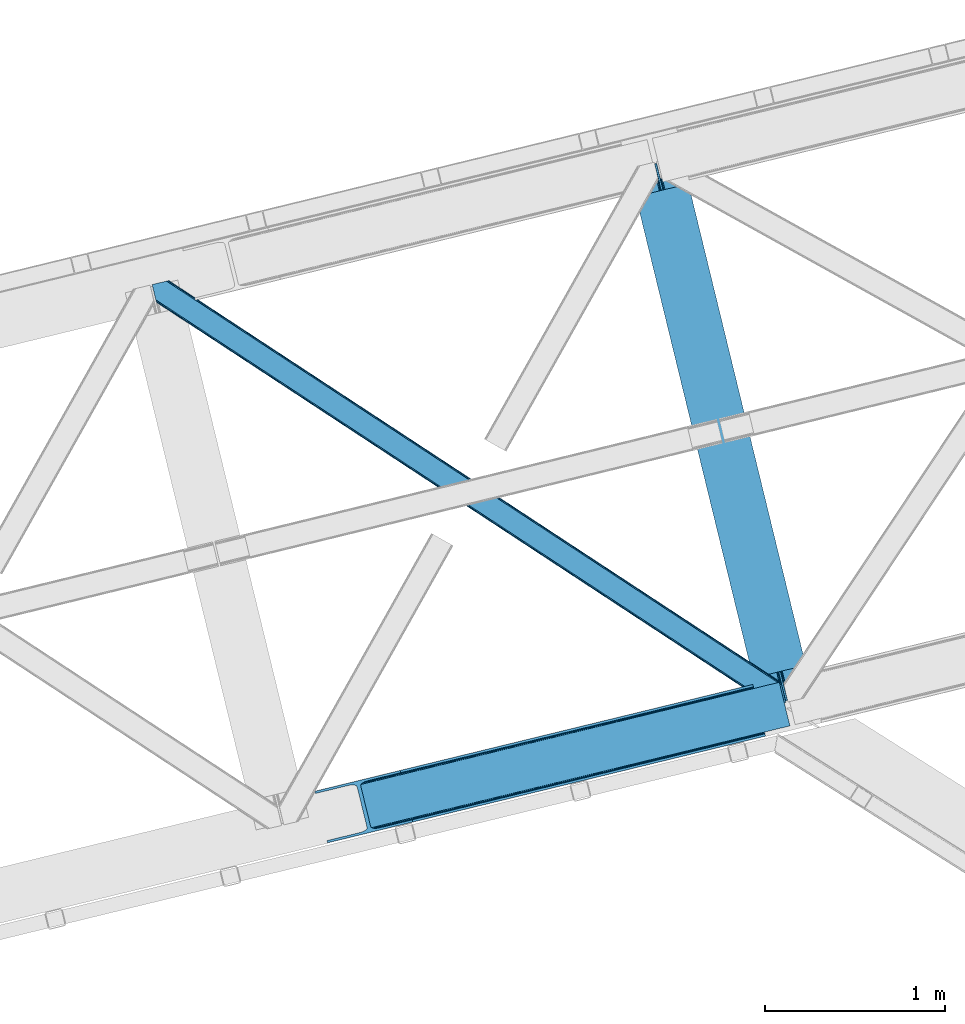
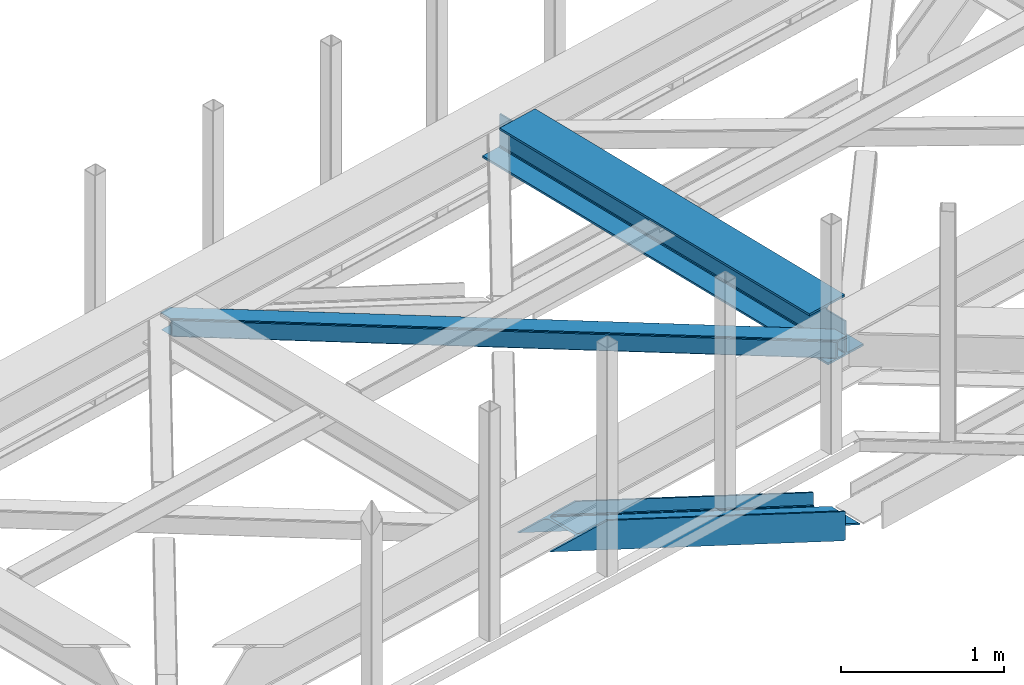
# One storey, part 56 of 67: 2 members, 1 beam.
"""IFC4 building model written with IfcOpenShell, lengths in millimetres."""

from ifc_helpers import new_model, entity, si_unit, converted_unit, derived_unit, direction, frame, origin, place, context, subcontext, project, spatial, triangles, polygons, material, type_object, element, save


model = new_model("IFC4")

# Units and contexts
model_context = context("Model", 3, precision=0.01, world=origin(), true_north=direction((6.12303176911189e-17, 1.0)))
plan_context = context("Plan", 3, precision=0.01, world=origin(), true_north=direction((6.12303176911189e-17, 1.0)))
body_context = subcontext(model_context, "Body", "Model", "MODEL_VIEW")
ifc_project = project(units=[si_unit("LENGTHUNIT", "METRE", prefix="MILLI"), si_unit("AREAUNIT", "SQUARE_METRE"), si_unit("VOLUMEUNIT", "CUBIC_METRE"), converted_unit("PLANEANGLEUNIT", "DEGREE", entity("IfcRatioMeasure", 0.0174532925199433), si_unit("PLANEANGLEUNIT", "RADIAN"), dimensions=[0, 0, 0, 0, 0, 0, 0]), si_unit("MASSUNIT", "GRAM", prefix="KILO"), derived_unit("MASSDENSITYUNIT", [(si_unit("MASSUNIT", "GRAM", prefix="KILO"), 1), (si_unit("LENGTHUNIT", "METRE"), -3)]), derived_unit("MOMENTOFINERTIAUNIT", [(si_unit("LENGTHUNIT", "METRE"), 4)]), si_unit("TIMEUNIT", "SECOND"), si_unit("FREQUENCYUNIT", "HERTZ"), si_unit("THERMODYNAMICTEMPERATUREUNIT", "DEGREE_CELSIUS"), derived_unit("THERMALTRANSMITTANCEUNIT", [(si_unit("MASSUNIT", "GRAM", prefix="KILO"), 1), (si_unit("THERMODYNAMICTEMPERATUREUNIT", "KELVIN"), -1), (si_unit("TIMEUNIT", "SECOND"), -3)]), derived_unit("VOLUMETRICFLOWRATEUNIT", [(si_unit("LENGTHUNIT", "METRE"), 3), (si_unit("TIMEUNIT", "SECOND"), -1)]), derived_unit("MASSFLOWRATEUNIT", [(si_unit("MASSUNIT", "GRAM", prefix="KILO"), 1), (si_unit("TIMEUNIT", "SECOND"), -1)]), derived_unit("ROTATIONALFREQUENCYUNIT", [(si_unit("TIMEUNIT", "SECOND"), -1)]), si_unit("ELECTRICCURRENTUNIT", "AMPERE"), si_unit("ELECTRICVOLTAGEUNIT", "VOLT"), si_unit("POWERUNIT", "WATT"), si_unit("FORCEUNIT", "NEWTON", prefix="KILO"), si_unit("ILLUMINANCEUNIT", "LUX"), si_unit("LUMINOUSFLUXUNIT", "LUMEN"), si_unit("LUMINOUSINTENSITYUNIT", "CANDELA"), derived_unit("USERDEFINED", [(si_unit("MASSUNIT", "GRAM", prefix="KILO"), -1), (si_unit("LENGTHUNIT", "METRE"), -2), (si_unit("TIMEUNIT", "SECOND"), 3), (si_unit("LUMINOUSFLUXUNIT", "LUMEN"), 1)]), derived_unit("LINEARVELOCITYUNIT", [(si_unit("LENGTHUNIT", "METRE"), 1), (si_unit("TIMEUNIT", "SECOND"), -1)]), si_unit("PRESSUREUNIT", "PASCAL"), derived_unit("USERDEFINED", [(si_unit("LENGTHUNIT", "METRE"), -2), (si_unit("MASSUNIT", "GRAM", prefix="KILO"), 1), (si_unit("TIMEUNIT", "SECOND"), -2)]), derived_unit("LINEARFORCEUNIT", [(si_unit("MASSUNIT", "GRAM", prefix="KILO"), 1), (si_unit("LENGTHUNIT", "METRE"), 1), (si_unit("TIMEUNIT", "SECOND"), -2), (si_unit("LENGTHUNIT", "METRE"), -1)]), derived_unit("PLANARFORCEUNIT", [(si_unit("MASSUNIT", "GRAM", prefix="KILO"), 1), (si_unit("LENGTHUNIT", "METRE"), 1), (si_unit("TIMEUNIT", "SECOND"), -2), (si_unit("LENGTHUNIT", "METRE"), -2)])], contexts=[model_context, plan_context])

# Site, building, storey
site_placement = place(None, origin())
site = spatial("IfcSite", under=ifc_project, at=site_placement, CompositionType="ELEMENT")
building_placement = place(site_placement, origin())
building = spatial("IfcBuilding", under=site, at=building_placement, CompositionType="ELEMENT")
storey_placement = place(building_placement, frame((0.0, 0.0, 19800.0)))
storey = spatial("IfcBuildingStorey", under=building, at=storey_placement, CompositionType="ELEMENT", Elevation=19800.0)

# Beam
ifc_material = material(Name="Metal painted (White)")
beam_type = type_object("IfcBeamType", PredefinedType="BEAM")
beam_placement = place(storey_placement, frame((-6288.26277255581, 16262.0986333316, 3807.02022389142)))
element("IfcBeam", 1, at=beam_placement, inside=storey, type_object=beam_type, material=ifc_material, ObjectType="Steel Beam", PredefinedType="BEAM", context=body_context, shape_type="Tessellation", body=[
    polygons([(1018.1664837833, 71.0478278971021, 15.5000000000008), (1018.1664837833, 71.0478278971021, 0.0), (291.465617442446, 3052.25531830421, 0.0), (291.465617442446, 3052.25531830421, 15.5000000000008), (894.779372399328, 40.970914087327, 15.5000000000008), (168.078506058477, 3022.17840449444, 15.5000000000008), (888.08702862538, 39.3395844888265, 16.8701684147984), (161.386162284532, 3020.54707489594, 16.8701684147984), (882.413533524755, 37.956610033654, 20.7720779386478), (155.712667183905, 3019.16410044076, 20.7720779386478), (878.622625296183, 37.0325360459184, 26.6116982174294), (151.921758955332, 3018.24002645303, 26.6116982174294), (877.291435352789, 36.7080444135029, 33.500000000001), (150.590569011938, 3017.91553482062, 33.500000000001), (140.875048430522, 3015.54727389071, 33.500000000001), (140.875048430529, 3015.54727389071, 259.000000000002), (150.590569011936, 3017.91553482062, 259.000000000002), (0.0, 2981.20749040711, 0.0), (3.24860138789518e-12, 2981.20749040711, 15.4999999999965), (123.387111383973, 3011.28440421689, 15.5000000000008), (130.079455157929, 3012.91573381539, 16.8701684147984), (135.752950258543, 3014.29870827056, 20.7720779386391), (139.543858487125, 3015.2227822583, 26.6116982174294), (877.291435352786, 36.7080444135051, 259.000000000002), (867.575914771381, 34.3397834836014, 259.000000000002), (867.575914771373, 34.3397834836014, 33.500000000001), (866.244724827976, 34.0152918511859, 26.6116982174294), (862.453816599394, 33.0912178634502, 20.7720779386391), (856.780321498778, 31.70824340828, 16.8701684147984), (850.087977724824, 30.076913809773, 15.5000000000008), (726.700866340854, 0.0, 15.4999999999965), (726.700866340851, 0.0, 0.0), (838.124523615913, 197.385937999179, 259.069791973884), (186.469722099971, 2870.72539801218, 259.000000000002), (186.693115201822, 2869.8089536072, 259.617303331124), (186.70550404545, 2869.75812937344, 266.500003008253), (837.979344808147, 197.981416001704, 266.500002998871), (837.979694928899, 197.979979696973, 260.000004007589), (828.499586345894, 194.645865944436, 259.006343171919), (828.276216326132, 195.562317481916, 259.617303331124), (828.263827482502, 195.613141715689, 266.500003008253), (176.989986719804, 2867.38985508742, 266.500002998871), (176.989636599053, 2867.39129139215, 260.000004007589), (176.844830940719, 2867.98534020595, 259.07612046749), (176.75420151856, 2868.35713708228, 259.000000000002), (839.310832678078, 198.30468544639, 273.388305639783), (843.101109266765, 199.231350618303, 279.227924098781), (848.774180214308, 200.616065081983, 283.129832400619), (855.466371895431, 202.248018612794, 284.500000377224), (978.853400583268, 232.325271667905, 284.500000138971), (978.851730776622, 232.332121736639, 299.999995328161), (687.386308679347, 161.283492472594, 299.999995890962), (687.387978486002, 161.276642403863, 284.500000701776), (810.77500717385, 191.353895458972, 284.500000463519), (817.467494069993, 192.984637925553, 283.129832461069), (823.141405718744, 194.365903570079, 279.227924137322), (826.932940505748, 195.287407219375, 273.388305663684), (175.658498849865, 2867.06658564273, 273.388305639783), (171.868222261161, 2866.13992047082, 279.227924098781), (166.195151313634, 2864.75520600714, 283.129832400619), (159.502959632503, 2863.12325247633, 284.500000377228), (36.1159309446587, 2833.04599942122, 284.500000138971), (36.117600751305, 2833.03914935249, 299.999995328161), (327.583022848579, 2904.08777861653, 299.999995890962), (327.581353041926, 2904.09462868526, 284.500000701776), (204.194324354083, 2874.01737563015, 284.500000463519), (197.501837457949, 2872.38663316357, 283.129832461069), (191.827925809181, 2871.00536751904, 279.227924137318), (188.036391022195, 2870.08386386975, 273.388305663684)], [[[1, 2, 3, 4]], [[5, 1, 4, 6]], [[7, 5, 6, 8]], [[9, 7, 8, 10]], [[11, 9, 10, 12]], [[13, 11, 12, 14]], [[15, 16, 17, 14, 12, 10, 8, 6, 4, 3, 18, 19, 20, 21, 22, 23]], [[13, 24, 25, 26, 27, 28, 29, 30, 31, 32, 2, 1, 5, 7, 9, 11]], [[2, 32, 18, 3]], [[32, 31, 19, 18]], [[31, 30, 20, 19]], [[27, 26, 15, 23]], [[28, 27, 23, 22]], [[29, 28, 22, 21]], [[30, 29, 21, 20]], [[33, 24, 13, 14, 17, 34, 35, 36, 37, 38]], [[25, 39, 40, 41, 42, 43, 44, 16, 15, 26]], [[39, 25, 24, 33]], [[45, 34, 17, 16]], [[41, 40, 38, 37, 46, 47, 48, 49, 50, 51, 52, 53, 54, 55, 56, 57]], [[42, 58, 59, 60, 61, 62, 63, 64, 65, 66, 67, 68, 69, 36, 35, 43]], [[46, 37, 36, 69]], [[47, 46, 69, 68]], [[48, 47, 68, 67]], [[49, 48, 67, 66]], [[50, 49, 66, 65]], [[51, 50, 65, 64]], [[52, 51, 64, 63]], [[53, 52, 63, 62]], [[54, 53, 62, 61]], [[55, 54, 61, 60]], [[56, 55, 60, 59]], [[57, 56, 59, 58]], [[41, 57, 58, 42]]], closed=False),
])

# Members
member_type_1 = type_object("IfcMemberType", PredefinedType="BRACE")
member_1_placement = place(storey_placement, frame((-8033.12245788574, 15508.6289520264, 2584.39182128906)))
element("IfcMember", 2, at=member_1_placement, inside=storey, type_object=member_type_1, ObjectType="Steel Vertical Brace", PredefinedType="BRACE", context=body_context, shape_type="Tessellation", body=[
    triangles([(2635.93561706543, 649.181304931641, 33.9583923339851), (2634.040965271, 656.954086303711, 33.9583923339851), (2635.12520141602, 650.127758789064, 32.7096313476541), (2635.1856628418, 648.998757934571, 32.2491943359382), (2635.93561706543, 649.181304931641, 45.3390930175774), (2495.05991363525, 614.841540527344, 97.2405761718728), (2495.05991363525, 614.841540527344, 110.67696533203), (2634.040965271, 656.954086303711, 43.2810791015618), (309.064274597168, 90.2154235839844, 1121.6082824707), (313.935488891601, 84.3134582519542, 1121.6082824707), (2635.65947113037, 650.313793945314, 45.0391113281257), (324.545306396484, 80.8892486572277, 1121.6082824707), (2496.17961273193, 610.247634887695, 114.402319335935), (2497.10397491455, 606.457168579102, 120.806579589844), (339.278128051758, 80.4636932373051, 1121.6082824707), (2497.42837371826, 605.125854492188, 128.361932373045), (355.892230224609, 83.1042297363292, 1121.6082824707), (2497.42837371826, 605.125854492188, 213.642773437499), (539.761820983887, 127.923587036134, 1121.6082824707), (2500.5072555542, 592.495230102541, 213.642773437499), (542.840702819824, 115.294125366212, 1121.6082824707), (2578.86061248779, 883.325152587891, 43.2810791015618), (253.883921813965, 316.587652587892, 1121.6082824707), (2500.5072555542, 592.495230102541, 2.47891845702907), (2497.42837371826, 605.125854492188, 79.5532836914063), (2497.42837371826, 605.125854492188, 2.47891845702907), (2497.10397491455, 606.457168579102, 87.1086364746079), (2496.17961273193, 610.247634887695, 93.5152221679673), (287.352809143066, 77.833621215821, 1121.6082824707), (279.509101867676, 69.9108489990249, 1121.6082824707), (288.961431884766, 85.3157226562507, 1121.6082824707), (266.619772338868, 62.7531463623054, 1121.6082824707), (250.654467773437, 57.4511444091804, 1121.6082824707), (2488.16672973633, 589.487274169922, 0.0), (69.8637588500978, 0.0, 1121.6082824707), (2485.08784790039, 602.117898559571, 0.0), (66.78487701416, 12.6306243896488, 1121.6082824707), (2578.86061248779, 883.325152587891, 33.9583923339851), (233.781079101563, 311.686788940431, 1121.6082824707), (2576.96596069336, 891.097933959962, 33.9583923339851), (2577.24210662842, 889.964282226563, 45.0391113281257), (2576.96596069336, 891.097933959962, 45.3390930175774), (2576.68225708008, 889.884054565431, 32.7096313476541), (2576.21542510986, 890.91538696289, 32.2491943359382), (2436.09025726318, 856.758169555666, 97.2405761718728), (2436.09025726318, 856.758169555666, 110.67696533203), (255.492544555665, 324.069754028322, 1121.6082824707), (263.336251831055, 331.992526245118, 1121.6082824707), (2434.9705581665, 861.350912475587, 114.402319335935), (2434.04677734375, 865.142541503907, 120.806579589844), (276.220930480958, 339.14906616211, 1121.6082824707), (2433.72179718018, 866.472692871095, 128.361932373045), (292.186235046387, 344.451068115235, 1121.6082824707), (2434.9705581665, 861.350912475587, 93.5152221679673), (228.909864807129, 317.589916992189, 1121.6082824707), (218.299465942383, 321.014126586915, 1121.6082824707), (2433.72179718018, 866.472692871095, 79.5532836914063), (2434.04677734375, 865.142541503907, 87.1086364746079), (203.562574768067, 321.43851928711, 1121.6082824707), (186.948472595215, 318.797982788086, 1121.6082824707), (2433.72179718018, 866.472692871095, 213.642773437499), (476.055825805664, 389.271588134767, 1121.6082824707), (2430.6434967041, 879.103317260742, 213.642773437499), (472.976943969727, 401.901049804688, 1121.6082824707), (0.0, 286.608087158203, 1121.6082824707), (3.07888183593786, 273.978625488282, 1121.6082824707), (2430.6434967041, 879.103317260742, 2.47891845702907), (2433.72179718018, 866.472692871095, 2.47891845702907), (2418.30297088623, 876.095361328127, 0.0), (2421.38185272217, 863.464736938477, 0.0)], [[1, 2, 3], [3, 4, 1], [4, 5, 6], [5, 4, 1], [7, 6, 5], [8, 9, 10], [11, 10, 7], [7, 10, 12], [12, 13, 7], [7, 5, 11], [14, 13, 15], [12, 15, 13], [16, 14, 17], [15, 17, 14], [10, 11, 8], [18, 16, 19], [17, 19, 16], [20, 18, 21], [19, 21, 18], [8, 22, 23], [23, 9, 8], [24, 25, 16], [26, 25, 24], [16, 25, 14], [16, 20, 24], [18, 20, 16], [14, 25, 27], [27, 28, 13], [28, 6, 13], [7, 13, 6], [13, 14, 27], [29, 3, 6], [6, 30, 29], [6, 28, 30], [3, 4, 6], [2, 3, 31], [29, 31, 3], [28, 27, 30], [32, 30, 27], [27, 25, 32], [33, 32, 25], [34, 20, 21], [20, 34, 24], [21, 35, 34], [25, 36, 33], [25, 26, 36], [37, 33, 36], [36, 34, 35], [35, 37, 36], [26, 24, 36], [34, 36, 24], [38, 2, 39], [31, 39, 2], [22, 38, 8], [40, 22, 41], [22, 40, 38], [41, 42, 40], [2, 8, 38], [8, 1, 11], [1, 8, 2], [5, 11, 1], [38, 40, 43], [44, 43, 40], [42, 44, 45], [42, 40, 44], [45, 46, 42], [47, 41, 46], [46, 48, 47], [46, 49, 48], [41, 42, 46], [22, 41, 47], [47, 23, 22], [49, 50, 51], [51, 48, 49], [50, 52, 53], [53, 51, 50], [54, 45, 55], [55, 56, 54], [57, 58, 59], [59, 60, 57], [58, 54, 56], [56, 59, 58], [44, 43, 45], [55, 45, 43], [43, 38, 39], [39, 55, 43], [52, 61, 62], [62, 53, 52], [61, 63, 62], [64, 62, 63], [9, 23, 31], [48, 51, 59], [53, 64, 65], [62, 64, 53], [51, 53, 60], [23, 47, 55], [47, 48, 56], [12, 32, 15], [21, 17, 35], [17, 15, 33], [21, 19, 17], [12, 10, 30], [10, 9, 29], [31, 23, 39], [60, 59, 51], [55, 47, 56], [59, 56, 48], [55, 39, 23], [65, 60, 53], [65, 66, 60], [33, 15, 32], [30, 10, 29], [31, 29, 9], [30, 32, 12], [33, 35, 17], [35, 33, 37], [50, 58, 57], [45, 54, 49], [54, 58, 49], [50, 49, 58], [49, 46, 45], [57, 67, 52], [67, 57, 68], [63, 52, 67], [57, 52, 50], [63, 61, 52], [63, 69, 64], [63, 67, 69], [65, 64, 69], [70, 57, 60], [57, 70, 68], [60, 66, 70], [69, 70, 65], [66, 65, 70], [67, 68, 69], [70, 69, 68]]),
])
member_type_2 = type_object("IfcMemberType", PredefinedType="BRACE")
member_2_placement = place(storey_placement, frame((-8936.90333862305, 16267.696572876, 3822.99993896484)))
element("IfcMember", 3, at=member_2_placement, inside=storey, type_object=member_type_2, ObjectType="Steel Horizontal Brace", PredefinedType="BRACE", context=body_context, shape_type="Tessellation", body=[
    triangles([(2937.3747756958, 494.994204711913, 17.5012573242202), (3489.95558166504, 132.252392578126, 122.499499511719), (3489.95558166504, 132.252392578126, 17.5012573242202), (2363.74234771729, 871.557266235353, 17.5012573242202), (1790.1046875, 1248.11916503906, 17.5012573242202), (93.3082580566406, 2361.98373413086, 122.499499511719), (642.839250183106, 2001.24645080566, 17.5012573242202), (93.3082580566406, 2361.98373413086, 17.5012573242202), (1216.47167816162, 1624.68338928223, 17.5012573242202), (3496.03021087647, 107.330657958984, 140.00075683594), (3493.7053527832, 116.868447875977, 138.668280029298), (70.0556076049816, 2356.31547546387, 140.00075683594), (78.9527389526374, 2358.48394775391, 138.668280029298), (3491.73454284668, 124.952838134765, 134.87548828125), (86.4987899780281, 2360.32337036133, 134.87548828125), (3490.41776275635, 130.355996704102, 129.196765136719), (91.5368545532237, 2361.55236511231, 129.196765136719), (18.1488922119152, 2264.78501586914, 140.00075683594), (0.0, 2339.23861083984, 140.00075683594), (3459.56150665283, 5.66825866699219, 140.00075683594), (3517.37658233643, 19.761584472657, 140.00075683594), (3436.30885620117, 0.0, 122.499499511719), (3438.08025970459, 0.431369018555415, 129.196765136719), (24.2235214233406, 2239.86328125, 122.499499511719), (23.761340332032, 2241.75967712402, 129.196765136719), (3443.11832427979, 1.66036376953161, 134.87548828125), (22.4445602416999, 2247.16283569336, 134.87548828125), (3450.66437530518, 3.49978637695313, 138.668280029298), (20.4737503051765, 2255.24722595215, 138.668280029298), (1731.79080505371, 1118.9293762207, 17.5012573242202), (2308.03237609863, 740.658279418947, 17.5012573242202), (2884.26987762451, 362.387182617187, 17.5012573242202), (3436.30885620117, 0.0, 17.5012573242202), (1155.5538848877, 1497.20163574219, 17.5012573242202), (579.31696472168, 1875.47389526367, 17.5012573242202), (24.2235214233406, 2239.86328125, 17.5012573242202), (21.3312561035164, 2251.72883605957, 122.197192382813), (20.0144760131843, 2257.13083190918, 127.873590087893), (21.7934371948249, 2249.83127746582, 115.499926757813), (21.7934371948249, 2249.83127746582, 24.5008300781265), (21.3312561035164, 2251.72883605957, 17.8035644531265), (20.1470260620117, 2256.58667907715, 12.5201660156272), (23.9723739624023, 2240.89345092773, 12.5201660156272), (18.0436660766609, 2265.2163848877, 131.668707275392), (15.7188079833995, 2274.75301208496, 133.001184082033), (0.0, 2339.23861083984, 133.001184082033), (3468.86500854492, 7.93556213378906, 133.001184082033), (3459.96322631836, 5.76592712402453, 131.668707275392), (3452.42182617188, 3.92766723632849, 127.873590087893), (3447.37911071777, 2.69867248535229, 122.197192382813), (3445.60770721436, 2.26730346679688, 115.499926757813), (3445.60770721436, 2.26730346679688, 24.5008300781265), (60.7521057128906, 2354.04817199707, 133.001184082033), (3498.46029510498, 97.3626617431637, 133.001184082033), (3517.37658233643, 19.761584472657, 133.001184082033), (23.177655029298, 2261.84798583984, 8.3320495605476), (3452.42182617188, 3.92766723632849, 12.1248413085959), (3447.37911071777, 2.69867248535229, 17.8035644531265), (3459.96322631836, 5.76592712402453, 8.3320495605476), (3468.86500854492, 7.93556213378906, 6.99957275390625), (22.4835113525387, 2270.31258544922, 6.99957275390625), (31.1539123535167, 2240.98763122559, 5.52059326172093), (6.80016632080151, 2340.89664916992, 5.52059326172093), (5.36304473876953, 2340.54667053223, 6.99957275390625), (25.5711135864258, 2240.91437988281, 10.9621215820334), (3492.38508453369, 122.284396362304, 115.499926757813), (3492.84784698486, 120.386837768556, 122.197192382813), (82.2380035400402, 2359.28506164551, 122.197192382813), (84.0047561645515, 2359.71526794434, 115.499926757813), (3494.1646270752, 114.984841918946, 127.873590087893), (77.1952880859371, 2358.05606689453, 127.873590087893), (3496.13543701172, 106.899288940431, 131.668707275392), (69.6533065795902, 2356.21780700683, 131.668707275392), (60.7521057128906, 2354.04817199707, 6.99957275390625), (87.0045730590828, 2360.44661865234, 5.52059326172093), (69.6533065795902, 2356.21780700683, 8.3320495605476), (82.2380035400402, 2359.28506164551, 17.8035644531265), (77.1952880859371, 2358.05606689453, 12.1248413085959), (84.0047561645515, 2359.71526794434, 24.5008300781265), (91.5368545532237, 2361.55236511231, 10.8039916992202), (3492.38508453369, 122.284396362304, 24.5008300781265), (3490.20672912598, 131.222222900391, 12.5201660156272), (3492.84784698486, 120.386837768556, 17.8035644531265), (3494.03207702637, 115.528994750977, 12.5201660156272), (3491.69559173584, 101.803088378907, 6.99957275390625), (3512.01295623779, 18.4535247802742, 6.99957275390625), (3491.00144805908, 110.267687988282, 8.3320495605476), (3442.61195983887, 1.53595275878979, 5.52059326172093), (3438.08025970459, 0.431369018555415, 10.8039916992202), (3510.57583465576, 18.1035461425781, 5.52059326172093), (3483.024609375, 131.129205322266, 5.52059326172093), (3488.60798950195, 131.201293945314, 10.9621215820334), (31.1539123535167, 2240.98763122559, 5.43687744140698), (87.0045730590828, 2360.44661865234, 5.55547485351781), (164.75099029541, 2309.41019897461, 5.51594238281177), (6.80016632080151, 2340.89664916992, 5.52989501953198), (146.797434997559, 2165.60502319336, 5.37874145507885), (196.831590270996, 2177.801953125, 5.39734497070458), (163.159226989746, 2169.5943145752, 0.0), (196.831590270996, 2177.801953125, 5.52059326172093), (197.80304260254, 2178.03914794922, 0.0), (146.797434997559, 2165.60618591309, 5.21363525390552), (154.262095642091, 2167.42467956543, 1.33247680664135), (197.80304260254, 2178.03914794922, 4.52065429687718), (166.329963684082, 2307.15452270508, 4.52065429687718), (170.404133605958, 2290.43926391602, 0.0), (168.079856872559, 2299.97589111328, 1.33247680664135), (3361.49423675537, 210.37553100586, 5.21363525390552), (2936.64575042725, 493.881481933595, 10.8039916992202), (2934.56099395752, 490.70958251953, 5.12526855468968), (3354.03422698975, 208.557037353517, 1.33247680664135), (640.024887084961, 1996.96066589355, 5.12526855468968), (636.907635498048, 1992.21444396973, 1.33247680664135), (642.105574035644, 2000.13140258789, 10.8039916992202), (165.5428024292, 2308.28236083984, 5.02062377929906), (164.75099029541, 2309.41019897461, 5.52059326172093), (633.231115722656, 1986.6147857666, 0.0), (3345.13244476318, 206.387402343751, 0.0), (2931.44781188965, 485.963360595704, 1.33247680664135), (2927.77187347412, 480.364865112306, 0.0), (2363.00867156982, 870.443380737304, 10.8039916992202), (1789.37566223145, 1247.00644226074, 10.8039916992202), (1215.73800201416, 1623.56834106445, 10.8039916992202), (2360.928565979, 867.272644042971, 5.12526855468968), (1787.29090576172, 1243.83454284668, 5.12526855468968), (1213.65789642334, 1620.39760437012, 5.12526855468968), (2357.81073303223, 862.526422119141, 1.33247680664135), (1784.17772369385, 1239.08948364258, 1.33247680664135), (1210.54471435547, 1615.65254516601, 1.33247680664135), (2354.13886413574, 856.927926635743, 0.0), (1780.50178527832, 1233.48982543945, 0.0), (1206.86877593994, 1610.05288696289, 0.0), (588.919866943359, 1890.10323486328, 0.0), (1165.15678710938, 1511.8309753418, 0.0), (1741.39428863525, 1133.55871582031, 0.0), (2893.87277984619, 377.016522216798, 0.0), (2317.63585968018, 755.287619018554, 0.0), (3315.15636749268, 199.079708862306, 0.0), (3343.77438812256, 81.6775726318356, 0.0), (2884.99890289307, 363.499905395509, 10.8039916992202), (2887.07900848389, 366.670642089843, 5.12526855468968), (3348.63630065918, 63.8333129882813, 5.02062377929906), (580.045989990234, 1876.58661804199, 10.8039916992202), (582.130746459961, 1879.75851745605, 5.12526855468968), (2890.19684143066, 371.416864013672, 1.33247680664135), (3346.09924621582, 72.1397827148448, 1.33247680664135), (3347.8491394043, 64.9611511230469, 4.52065429687718), (585.243928527832, 1884.50473937988, 1.33247680664135), (3349.42811279297, 62.7054748535156, 5.52059326172093), (2313.95933990479, 749.689123535156, 1.33247680664135), (1737.72241973877, 1127.96138305664, 1.33247680664135), (1161.48084869385, 1506.2324798584, 1.33247680664135), (2310.84208831787, 744.94290161133, 5.12526855468968), (1734.60458679199, 1123.21516113281, 5.12526855468968), (1158.36766662598, 1501.48625793457, 5.12526855468968), (2308.76198272705, 741.772164916993, 10.8039916992202), (1732.52448120117, 1120.04442443848, 10.8039916992202), (1156.28756103516, 1498.31552124024, 10.8039916992202), (3349.42811279297, 62.7054748535156, 5.51129150390625), (3361.49423675537, 210.37553100586, 5.38339233398438), (3483.024609375, 131.129205322266, 5.43687744140698), (3316.12781982422, 199.316903686524, 5.39734497070458), (3442.61195983887, 1.53595275878979, 5.55314941406323), (3510.57583465576, 18.1035461425781, 5.53222045898656), (3316.12781982422, 199.316903686524, 5.52059326172093), (3315.15636749268, 199.079708862306, 4.52065429687718)], [[1, 2, 3], [2, 1, 4], [2, 5, 6], [5, 2, 4], [7, 8, 6], [9, 6, 5], [6, 9, 7], [10, 11, 12], [13, 12, 11], [11, 14, 13], [15, 13, 14], [14, 16, 15], [17, 15, 16], [16, 2, 17], [6, 17, 2], [12, 18, 10], [12, 19, 18], [20, 10, 18], [21, 10, 20], [22, 23, 24], [25, 24, 23], [23, 26, 25], [27, 25, 26], [26, 28, 27], [29, 27, 28], [28, 20, 29], [18, 29, 20], [30, 22, 24], [22, 31, 32], [30, 31, 22], [32, 33, 22], [34, 24, 35], [24, 34, 30], [36, 35, 24], [37, 27, 38], [39, 40, 24], [25, 37, 24], [37, 25, 27], [37, 39, 24], [40, 36, 24], [41, 42, 43], [43, 36, 41], [40, 41, 36], [44, 29, 18], [19, 45, 18], [46, 45, 19], [44, 38, 29], [29, 38, 27], [45, 44, 18], [47, 48, 44], [44, 45, 47], [48, 49, 38], [38, 44, 48], [49, 50, 37], [37, 38, 49], [50, 51, 39], [39, 37, 50], [51, 52, 39], [40, 39, 52], [45, 53, 54], [53, 45, 46], [54, 47, 45], [55, 47, 54], [56, 42, 57], [57, 42, 41], [52, 58, 40], [41, 40, 58], [41, 58, 57], [57, 59, 56], [59, 60, 61], [61, 56, 59], [62, 61, 63], [61, 62, 56], [64, 63, 61], [42, 56, 62], [65, 43, 42], [65, 42, 62], [66, 67, 68], [68, 69, 66], [67, 70, 71], [71, 68, 67], [70, 72, 73], [73, 71, 70], [72, 54, 53], [53, 73, 72], [13, 12, 73], [19, 53, 12], [53, 19, 46], [53, 73, 12], [71, 13, 73], [71, 15, 13], [15, 68, 17], [68, 15, 71], [6, 68, 69], [68, 6, 17], [74, 75, 76], [77, 78, 75], [78, 76, 75], [74, 63, 75], [63, 74, 64], [79, 77, 8], [80, 8, 77], [6, 79, 8], [79, 6, 69], [77, 75, 80], [81, 66, 79], [69, 79, 66], [70, 14, 11], [14, 70, 67], [54, 72, 10], [72, 70, 11], [55, 54, 21], [10, 21, 54], [72, 11, 10], [82, 83, 84], [3, 2, 81], [81, 83, 3], [82, 3, 83], [2, 66, 81], [67, 16, 14], [2, 16, 67], [66, 2, 67], [74, 61, 85], [74, 64, 61], [60, 85, 61], [86, 85, 60], [78, 84, 83], [87, 84, 78], [85, 87, 76], [76, 74, 85], [78, 76, 87], [83, 77, 78], [83, 81, 77], [79, 77, 81], [49, 48, 28], [26, 49, 28], [50, 26, 23], [50, 22, 51], [26, 50, 49], [22, 50, 23], [48, 20, 28], [21, 47, 55], [21, 20, 47], [48, 47, 20], [22, 52, 51], [88, 57, 58], [58, 52, 33], [33, 52, 22], [58, 89, 88], [89, 58, 33], [90, 60, 88], [60, 59, 88], [59, 57, 88], [90, 86, 60], [84, 91, 92], [87, 91, 84], [92, 82, 84], [86, 90, 85], [85, 91, 87], [91, 85, 90], [93, 94, 95], [94, 93, 96], [95, 97, 93], [98, 97, 95], [99, 100, 101], [102, 99, 103], [101, 100, 104], [102, 100, 99], [105, 106, 104], [106, 105, 107], [101, 104, 106], [1, 82, 92], [1, 3, 82], [92, 91, 108], [108, 109, 92], [110, 108, 111], [112, 113, 107], [107, 105, 112], [114, 112, 115], [7, 114, 8], [80, 8, 114], [114, 116, 80], [75, 80, 116], [105, 115, 112], [113, 117, 106], [106, 107, 113], [111, 118, 119], [120, 119, 118], [111, 119, 110], [108, 110, 109], [92, 109, 1], [1, 109, 4], [121, 4, 109], [4, 121, 5], [122, 5, 121], [5, 122, 9], [123, 9, 122], [9, 123, 7], [114, 7, 123], [109, 110, 121], [124, 121, 110], [121, 124, 122], [125, 122, 124], [122, 125, 123], [126, 123, 125], [123, 126, 114], [112, 114, 126], [110, 119, 124], [127, 124, 119], [124, 127, 128], [128, 125, 124], [125, 128, 129], [129, 126, 125], [126, 129, 113], [113, 112, 126], [119, 120, 130], [130, 127, 119], [127, 130, 128], [131, 128, 130], [128, 131, 129], [132, 129, 131], [129, 132, 113], [117, 113, 132], [133, 99, 101], [117, 133, 101], [117, 101, 106], [132, 133, 117], [134, 133, 132], [131, 134, 132], [134, 131, 135], [120, 136, 137], [135, 130, 137], [130, 135, 131], [130, 120, 137], [120, 138, 136], [136, 138, 139], [118, 138, 120], [140, 141, 142], [35, 43, 65], [35, 36, 43], [65, 62, 102], [102, 143, 65], [144, 102, 103], [141, 145, 146], [146, 147, 141], [147, 142, 141], [139, 146, 145], [145, 136, 139], [133, 148, 99], [103, 99, 148], [103, 148, 144], [102, 144, 143], [65, 143, 35], [89, 33, 140], [32, 140, 33], [88, 89, 149], [140, 149, 89], [136, 145, 137], [150, 137, 145], [137, 150, 135], [151, 135, 150], [135, 151, 134], [152, 134, 151], [134, 152, 133], [148, 133, 152], [145, 141, 153], [153, 150, 145], [150, 153, 154], [154, 151, 150], [151, 154, 155], [155, 152, 151], [152, 155, 148], [144, 148, 155], [141, 140, 153], [156, 153, 140], [153, 156, 154], [157, 154, 156], [154, 157, 155], [158, 155, 157], [155, 158, 143], [143, 144, 155], [140, 32, 31], [31, 156, 140], [156, 31, 30], [30, 157, 156], [157, 30, 34], [34, 158, 157], [158, 34, 143], [35, 143, 34], [159, 160, 161], [160, 159, 162], [161, 163, 159], [164, 163, 161], [118, 165, 138], [108, 118, 111], [138, 165, 166], [108, 165, 118], [139, 166, 147], [139, 138, 166], [147, 146, 139]]),
])

save(model, "model.ifc")
